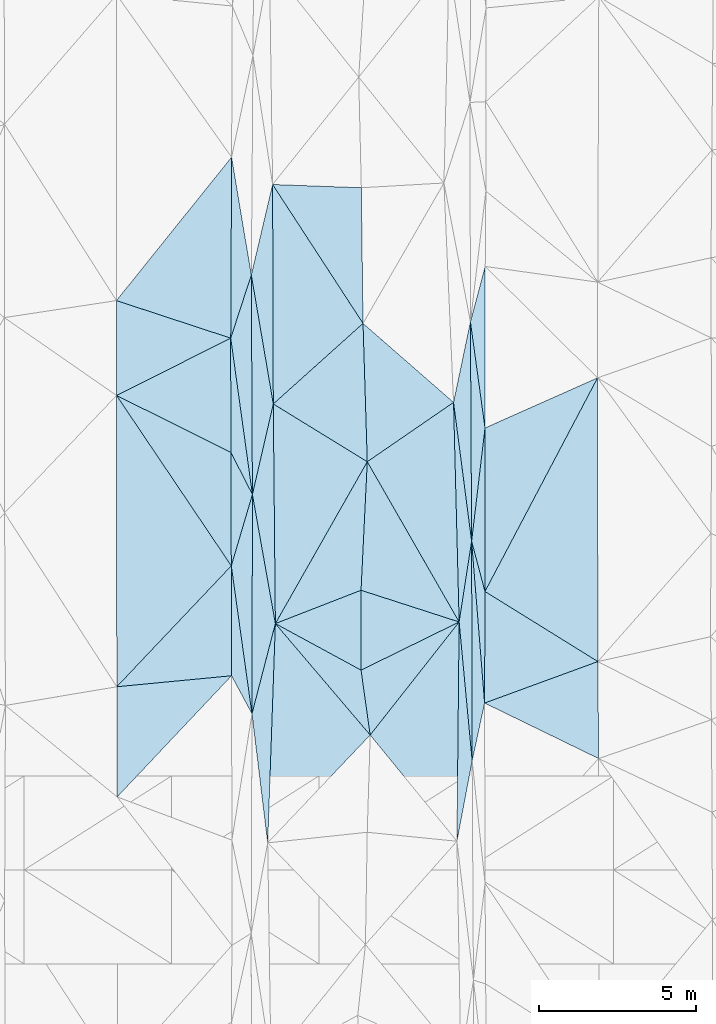
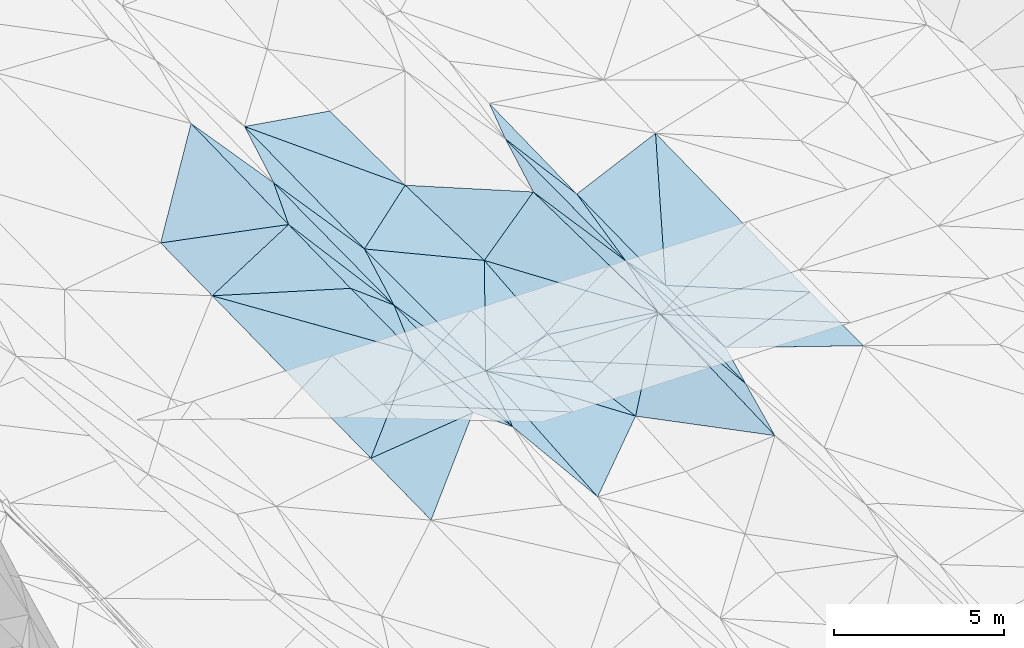
# One storey, part 108 of 275: 45 plates.
"""IFC2X3 building model written with IfcOpenShell, lengths in millimetres."""

from ifc_helpers import new_model, si_unit, frame, origin_with_axes, place, context, subcontext, project, spatial, polyline, outline, extrude, material, type_object, element, save


model = new_model("IFC2X3")

# Units and contexts
model_context = context("Model", 3, precision=1e-05, world=origin_with_axes())
body_context = subcontext(model_context, "Body", "Model", "MODEL_VIEW")
ifc_project = project(units=[si_unit("LENGTHUNIT", "METRE", prefix="MILLI"), si_unit("AREAUNIT", "SQUARE_METRE"), si_unit("VOLUMEUNIT", "CUBIC_METRE"), si_unit("MASSUNIT", "GRAM", prefix="KILO"), si_unit("TIMEUNIT", "SECOND"), si_unit("PLANEANGLEUNIT", "RADIAN"), si_unit("SOLIDANGLEUNIT", "STERADIAN"), si_unit("THERMODYNAMICTEMPERATUREUNIT", "DEGREE_CELSIUS"), si_unit("LUMINOUSINTENSITYUNIT", "LUMEN")], contexts=[model_context])

# Site, building, storey
site_placement = place(None, origin_with_axes())
site = spatial("IfcSite", under=ifc_project, at=site_placement, CompositionType="ELEMENT")
building_placement = place(site_placement, origin_with_axes())
building = spatial("IfcBuilding", under=site, at=building_placement, Name="Undefined", CompositionType="ELEMENT")
storey_placement = place(building_placement, origin_with_axes())
storey = spatial("IfcBuildingStorey", under=building, at=storey_placement, Name="Undefined", CompositionType="ELEMENT", Elevation=0.0)

# Plates
ifc_material = material()
plate_type_1 = type_object("IfcPlateType", PredefinedType="NOTDEFINED")
plate_1_placement = place(storey_placement, frame((-72857.8728708882, 71200.3635232612, 42820.5068189035), z_axis=(0.163382839514958, 0.0207850370122692, -0.986343768667105), x_axis=(-0.0100323754540099, -0.999691344366781, -0.022728120047394)))
element("IfcPlate", 1, at=plate_1_placement, inside=storey, type_object=plate_type_1, material=ifc_material, Name="00", context=body_context, shape_type="SweptSolid", body=[
    extrude(outline(polyline([(0.0, 0.0), (6995.7392578125, -1.95213942788541e-08), (3644.97436523438, 2839.29345703125), (0.0, 0.0)])), frame((-8.85201319254618e-08, 2.18876761149539e-07, -0.5000001331573), z_axis=(0.0, 0.0, 1.0), x_axis=(1.0, 0.0, 0.0)), (0.0, 0.0, 1.0), 1.0),
])
plate_type_2 = type_object("IfcPlateType", PredefinedType="NOTDEFINED")
plate_2_placement = place(storey_placement, frame((-79451.9608102486, 75268.5090388455, 42914.5001193451), z_axis=(0.00661582862626552, 0.0219756908270818, -0.999736615226361), x_axis=(-0.456254255472781, 0.889695770643281, 0.0165375349565078)))
element("IfcPlate", 2, at=plate_2_placement, inside=storey, type_object=plate_type_2, material=ifc_material, Name="00", context=body_context, shape_type="SweptSolid", body=[
    extrude(outline(polyline([(0.0, 0.0), (1511.71264648438, 4.15457179769874e-09), (4752.4609375, 1659.44287109375), (0.0, 0.0)])), frame((-8.85201319254618e-08, 2.18876761149539e-07, -0.5000001331573), z_axis=(0.0, 0.0, 1.0), x_axis=(1.0, 0.0, 0.0)), (0.0, 0.0, 1.0), 1.0),
])
plate_type_3 = type_object("IfcPlateType", PredefinedType="NOTDEFINED")
plate_3_placement = place(storey_placement, frame((-68432.6148026348, 69937.9228336085, 42759.5002629665), z_axis=(-0.0265998288897072, 0.0197490811271896, -0.999451060781702), x_axis=(-0.938788525447219, -0.344013537513872, 0.0181876467919163)))
element("IfcPlate", 3, at=plate_3_placement, inside=storey, type_object=plate_type_3, material=ifc_material, Name="00", context=body_context, shape_type="SweptSolid", body=[
    extrude(outline(polyline([(0.0, 0.0), (3848.76611328125, 1.68802216649055e-09), (2614.4482421875, 3338.61645507813), (0.0, 0.0)])), frame((-8.85201319254618e-08, 2.18876761149539e-07, -0.5000001331573), z_axis=(0.0, 0.0, 1.0), x_axis=(1.0, 0.0, 0.0)), (0.0, 0.0, 1.0), 1.0),
])
plate_type_4 = type_object("IfcPlateType", PredefinedType="NOTDEFINED")
plate_4_placement = place(storey_placement, frame((-80116.0807618143, 86027.7293392564, 43129.5004073985), z_axis=(0.0363448309060378, 0.0188605692333004, -0.999161314400536), x_axis=(-0.00477584441094, -0.999807192790456, -0.0190464840490176)))
element("IfcPlate", 4, at=plate_4_placement, inside=storey, type_object=plate_type_4, material=ifc_material, Name="00", context=body_context, shape_type="SweptSolid", body=[
    extrude(outline(polyline([(0.0, 0.0), (5775.34423828125, 8.13452061265707e-09), (4596.9208984375, 3653.87719726563), (0.0, 0.0)])), frame((-8.85201319254618e-08, 2.18876761149539e-07, -0.5000001331573), z_axis=(0.0, 0.0, 1.0), x_axis=(1.0, 0.0, 0.0)), (0.0, 0.0, 1.0), 1.0),
])
plate_type_5 = type_object("IfcPlateType", PredefinedType="NOTDEFINED")
plate_5_placement = place(storey_placement, frame((-80125.4359483068, 72990.6765646459, 42859.500226889), z_axis=(0.0262424867575079, 0.0163751317635468, -0.999521478983072), x_axis=(0.2834598154468, 0.958704684194832, 0.0231486831105507)))
element("IfcPlate", 5, at=plate_5_placement, inside=storey, type_object=plate_type_5, material=ifc_material, Name="00", context=body_context, shape_type="SweptSolid", body=[
    extrude(outline(polyline([(0.0, 0.0), (2375.94506835938, -1.05355866253376e-08), (-4338.8623046875, 1970.98706054688), (0.0, 0.0)])), frame((-8.85201319254618e-08, 2.18876761149539e-07, -0.5000001331573), z_axis=(0.0, 0.0, 1.0), x_axis=(1.0, 0.0, 0.0)), (0.0, 0.0, 1.0), 1.0),
])
plate_type_6 = type_object("IfcPlateType", PredefinedType="NOTDEFINED")
plate_6_placement = place(storey_placement, frame((-80143.6796963397, 80253.5000110002, 43019.5001044803), z_axis=(0.00276311446801479, 0.0214417133830076, -0.999766281750709), x_axis=(0.31008959754468, 0.950470010515551, 0.0212414831202224)))
element("IfcPlate", 6, at=plate_6_placement, inside=storey, type_object=plate_type_6, material=ifc_material, Name="00", context=body_context, shape_type="SweptSolid", body=[
    extrude(outline(polyline([(0.0, 0.0), (2118.49609375, 6.88305590301752e-09), (-4525.82080078125, 2203.76513671875), (0.0, 0.0)])), frame((-8.85201319254618e-08, 2.18876761149539e-07, -0.5000001331573), z_axis=(0.0, 0.0, 1.0), x_axis=(1.0, 0.0, 0.0)), (0.0, 0.0, 1.0), 1.0),
])
plate_type_7 = type_object("IfcPlateType", PredefinedType="NOTDEFINED")
plate_7_placement = place(storey_placement, frame((-79451.9889511648, 75268.5086278092, 42914.5007184932), z_axis=(-0.0496778021210665, 0.0211547469191174, -0.998541232328044), x_axis=(-0.00497029753528629, 0.99975804349267, 0.0214278000298448)))
element("IfcPlate", 7, at=plate_7_placement, inside=storey, type_object=plate_type_7, material=ifc_material, Name="00", context=body_context, shape_type="SweptSolid", body=[
    extrude(outline(polyline([(0.0, 0.0), (7000.251953125, 4.68135112896562e-08), (2882.32446289063, 681.223510742188), (0.0, 0.0)])), frame((-8.85201319254618e-08, 2.18876761149539e-07, -0.5000001331573), z_axis=(0.0, 0.0, 1.0), x_axis=(1.0, 0.0, 0.0)), (0.0, 0.0, 1.0), 1.0),
])
plate_type_8 = type_object("IfcPlateType", PredefinedType="NOTDEFINED")
plate_8_placement = place(storey_placement, frame((-72033.7376675861, 72172.6673554907, 42899.5006058297), z_axis=(-0.0449430024337479, 0.0210730985098259, -0.998767265708801), x_axis=(-0.25649921547482, 0.966017080441057, 0.0319241719851723)))
element("IfcPlate", 8, at=plate_8_placement, inside=storey, type_object=plate_type_8, material=ifc_material, Name="00", context=body_context, shape_type="SweptSolid", body=[
    extrude(outline(polyline([(0.0, 0.0), (1660.18408203125, 3.14321368932724e-09), (5041.82080078125, 1340.57641601563), (0.0, 0.0)])), frame((-8.85201319254618e-08, 2.18876761149539e-07, -0.5000001331573), z_axis=(0.0, 0.0, 1.0), x_axis=(1.0, 0.0, 0.0)), (0.0, 0.0, 1.0), 1.0),
])
plate_type_9 = type_object("IfcPlateType", PredefinedType="NOTDEFINED")
plate_9_placement = place(storey_placement, frame((-72442.4501093722, 66773.3408617365, 42803.5003700226), z_axis=(-0.0327809613251292, 0.0211799794004191, -0.99923811829173), x_axis=(-0.00244369959772996, 0.999770750871483, 0.0212714370493995)))
element("IfcPlate", 9, at=plate_9_placement, inside=storey, type_object=plate_type_9, material=ifc_material, Name="00", context=body_context, shape_type="SweptSolid", body=[
    extrude(outline(polyline([(0.0, 0.0), (7004.69873046875, -9.50240064412355e-09), (1839.71691894531, 401.367462158203), (0.0, 0.0)])), frame((-8.85201319254618e-08, 2.18876761149539e-07, -0.5000001331573), z_axis=(0.0, 0.0, 1.0), x_axis=(1.0, 0.0, 0.0)), (0.0, 0.0, 1.0), 1.0),
])
plate_type_10 = type_object("IfcPlateType", PredefinedType="NOTDEFINED")
plate_10_placement = place(storey_placement, frame((-75788.1193262219, 76312.1021307502, 42598.5034495006), z_axis=(-0.114202995446313, 0.027336586494193, -0.993081258946082), x_axis=(-0.0484452834658263, -0.998585350156554, -0.0219169560529661)))
element("IfcPlate", 10, at=plate_10_placement, inside=storey, type_object=plate_type_10, material=ifc_material, Name="00", context=body_context, shape_type="SweptSolid", body=[
    extrude(outline(polyline([(0.0, 0.0), (4106.40966796875, -5.67524693906307e-10), (5293.72412109375, 2695.96728515625), (0.0, 0.0)])), frame((-8.85201319254618e-08, 2.18876761149539e-07, -0.5000001331573), z_axis=(0.0, 0.0, 1.0), x_axis=(1.0, 0.0, 0.0)), (0.0, 0.0, 1.0), 1.0),
])
plate_type_11 = type_object("IfcPlateType", PredefinedType="NOTDEFINED")
plate_11_placement = place(storey_placement, frame((-80141.6859915911, 76613.4734157735, 42939.5001215529), z_axis=(0.00687262350337496, 0.0221072943769802, -0.999731981373763), x_axis=(0.45625425547646, -0.889695770641418, -0.0165375349552217)))
element("IfcPlate", 11, at=plate_11_placement, inside=storey, type_object=plate_type_11, material=ifc_material, Name="00", context=body_context, shape_type="SweptSolid", body=[
    extrude(outline(polyline([(0.0, 0.0), (1511.71264648438, 4.15457179769874e-09), (3231.91723632813, 1638.90539550781), (0.0, 0.0)])), frame((-8.85201319254618e-08, 2.18876761149539e-07, -0.5000001331573), z_axis=(0.0, 0.0, 1.0), x_axis=(1.0, 0.0, 0.0)), (0.0, 0.0, 1.0), 1.0),
])
plate_type_12 = type_object("IfcPlateType", PredefinedType="NOTDEFINED")
plate_12_placement = place(storey_placement, frame((-78964.5476860163, 64154.5708718856, 42611.5040899322), z_axis=(-0.124258073772401, 0.0301572693350512, -0.991791545743674), x_axis=(-0.120780756459142, 0.991645740550093, 0.0452850319423066)))
element("IfcPlate", 12, at=plate_12_placement, inside=storey, type_object=plate_type_12, material=ifc_material, Name="00", context=body_context, shape_type="SweptSolid", body=[
    extrude(outline(polyline([(0.0, 0.0), (4151.48193359375, 6.98491930961609e-10), (6914.49267578125, 1096.55187988281), (0.0, 0.0)])), frame((-8.85201319254618e-08, 2.18876761149539e-07, -0.5000001331573), z_axis=(0.0, 0.0, 1.0), x_axis=(1.0, 0.0, 0.0)), (0.0, 0.0, 1.0), 1.0),
])
plate_type_13 = type_object("IfcPlateType", PredefinedType="NOTDEFINED")
plate_13_placement = place(storey_placement, frame((-72442.3400560563, 66773.3409452281, 42803.5089563481), z_axis=(0.187315329686238, 0.021352629379972, -0.982067733144256), x_axis=(-0.0934486975000331, 0.995616755542285, 0.00382322102427208)))
element("IfcPlate", 13, at=plate_13_placement, inside=storey, type_object=plate_type_13, material=ifc_material, Name="00", context=body_context, shape_type="SweptSolid", body=[
    extrude(outline(polyline([(0.0, 0.0), (4446.51318359375, 3.11047188006341e-08), (6974.5654296875, 649.026062011719), (0.0, 0.0)])), frame((-8.85201319254618e-08, 2.18876761149539e-07, -0.5000001331573), z_axis=(0.0, 0.0, 1.0), x_axis=(1.0, 0.0, 0.0)), (0.0, 0.0, 1.0), 1.0),
])
plate_type_14 = type_object("IfcPlateType", PredefinedType="NOTDEFINED")
plate_14_placement = place(storey_placement, frame((-72928.0490013595, 64206.7833467757, 42661.5081633929), z_axis=(0.178893221706957, 0.0205682188323153, -0.983653477400132), x_axis=(0.0100323754560474, 0.999691344367152, 0.0227281200301465)))
element("IfcPlate", 14, at=plate_14_placement, inside=storey, type_object=plate_type_14, material=ifc_material, Name="00", context=body_context, shape_type="SweptSolid", body=[
    extrude(outline(polyline([(0.0, 0.0), (6995.7392578125, -1.95213942788541e-08), (2573.865234375, 467.447296142578), (0.0, 0.0)])), frame((-8.85201319254618e-08, 2.18876761149539e-07, -0.5000001331573), z_axis=(0.0, 0.0, 1.0), x_axis=(1.0, 0.0, 0.0)), (0.0, 0.0, 1.0), 1.0),
])
plate_type_15 = type_object("IfcPlateType", PredefinedType="NOTDEFINED")
plate_15_placement = place(storey_placement, frame((-75987.0012267293, 69663.9851055878, 42344.5061495304), z_axis=(-0.156066222917514, 0.0114360040365097, -0.987680389536989), x_axis=(0.139399294462836, -0.989669909413387, -0.0334859239825032)))
element("IfcPlate", 15, at=plate_15_placement, inside=storey, type_object=plate_type_15, material=ifc_material, Name="00", context=body_context, shape_type="SweptSolid", body=[
    extrude(outline(polyline([(0.0, 0.0), (2090.4306640625, -1.05646904557943e-08), (-1865.46740722656, 2528.67602539063), (0.0, 0.0)])), frame((-8.85201319254618e-08, 2.18876761149539e-07, -0.5000001331573), z_axis=(0.0, 0.0, 1.0), x_axis=(1.0, 0.0, 0.0)), (0.0, 0.0, 1.0), 1.0),
])
plate_type_16 = type_object("IfcPlateType", PredefinedType="NOTDEFINED")
plate_16_placement = place(storey_placement, frame((-79465.8887089548, 68271.3639608554, 42799.5003174788), z_axis=(0.0320064093374872, 0.017178357921229, -0.999340029109438), x_axis=(-0.472907201462392, 0.881112239618205, -4.77451848829258e-11)))
element("IfcPlate", 16, at=plate_16_placement, inside=storey, type_object=plate_type_16, material=ifc_material, Name="00", context=body_context, shape_type="SweptSolid", body=[
    extrude(outline(polyline([(0.0, 0.0), (1377.00903320313, -1.03027559816837e-08), (4470.14794921875, 1651.75463867188), (0.0, 0.0)])), frame((-8.85201319254618e-08, 2.18876761149539e-07, -0.5000001331573), z_axis=(0.0, 0.0, 1.0), x_axis=(1.0, 0.0, 0.0)), (0.0, 0.0, 1.0), 1.0),
])
plate_type_17 = type_object("IfcPlateType", PredefinedType="NOTDEFINED")
plate_17_placement = place(storey_placement, frame((-72857.8615490669, 71200.363916149, 42820.5088364232), z_axis=(0.186026571524622, 0.0215642566052026, -0.98230804614635), x_axis=(-0.0254378945506109, 0.999529713962518, 0.0171249650171869)))
element("IfcPlate", 17, at=plate_17_placement, inside=storey, type_object=plate_type_17, material=ifc_material, Name="00", context=body_context, shape_type="SweptSolid", body=[
    extrude(outline(polyline([(0.0, 0.0), (7007.3134765625, -2.31739250011742e-08), (2566.984375, 472.098236083984), (0.0, 0.0)])), frame((-8.85201319254618e-08, 2.18876761149539e-07, -0.5000001331573), z_axis=(0.0, 0.0, 1.0), x_axis=(1.0, 0.0, 0.0)), (0.0, 0.0, 1.0), 1.0),
])
plate_type_18 = type_object("IfcPlateType", PredefinedType="NOTDEFINED")
plate_18_placement = place(storey_placement, frame((-72045.803731531, 68613.8952442671, 42829.5007033956), z_axis=(-0.0496755244645198, 0.0198099526394931, -0.998568930042186), x_axis=(-0.0798702746437501, 0.996522466564578, 0.0237426380248853)))
element("IfcPlate", 18, at=plate_18_placement, inside=storey, type_object=plate_type_18, material=ifc_material, Name="00", context=body_context, shape_type="SweptSolid", body=[
    extrude(outline(polyline([(0.0, 0.0), (5180.55322265625, 2.29192664846778e-08), (3547.09423828125, 296.686370849609), (0.0, 0.0)])), frame((-8.85201319254618e-08, 2.18876761149539e-07, -0.5000001331573), z_axis=(0.0, 0.0, 1.0), x_axis=(1.0, 0.0, 0.0)), (0.0, 0.0, 1.0), 1.0),
])
plate_type_19 = type_object("IfcPlateType", PredefinedType="NOTDEFINED")
plate_19_placement = place(storey_placement, frame((-72857.9022795684, 71200.3615100847, 42820.5028025911), z_axis=(0.104563570142122, 0.0167518060830626, -0.994377109949786), x_axis=(-0.947297248148376, 0.306114359505968, -0.0944559291668124)))
element("IfcPlate", 19, at=plate_19_placement, inside=storey, type_object=plate_type_19, material=ifc_material, Name="00", context=body_context, shape_type="SweptSolid", body=[
    extrude(outline(polyline([(0.0, 0.0), (3303.12768554688, 6.29370333626866e-09), (4361.427734375, 3967.69458007813), (0.0, 0.0)])), frame((-8.85201319254618e-08, 2.18876761149539e-07, -0.5000001331573), z_axis=(0.0, 0.0, 1.0), x_axis=(1.0, 0.0, 0.0)), (0.0, 0.0, 1.0), 1.0),
])
plate_type_20 = type_object("IfcPlateType", PredefinedType="NOTDEFINED")
plate_20_placement = place(storey_placement, frame((-72459.5670428774, 73776.4327170666, 42952.5003377471), z_axis=(-0.0318865400626018, 0.0195382723737591, -0.999300507592929), x_axis=(-0.00543729468210168, 0.999790730093737, 0.0197213550541615)))
element("IfcPlate", 20, at=plate_20_placement, inside=storey, type_object=plate_type_20, material=ifc_material, Name="00", context=body_context, shape_type="SweptSolid", body=[
    extrude(outline(polyline([(0.0, 0.0), (6997.49072265625, -6.11180439591408e-09), (3610.12182617188, 446.801147460938), (0.0, 0.0)])), frame((-8.85201319254618e-08, 2.18876761149539e-07, -0.5000001331573), z_axis=(0.0, 0.0, 1.0), x_axis=(1.0, 0.0, 0.0)), (0.0, 0.0, 1.0), 1.0),
])
plate_type_21 = type_object("IfcPlateType", PredefinedType="NOTDEFINED")
plate_21_placement = place(storey_placement, frame((-72032.6153777705, 77388.5096025226, 43009.5001307363), z_axis=(-0.00467191600541404, 0.0232877985675683, -0.99971788602521), x_axis=(-0.136091631589599, 0.990412562913072, 0.0237070250187935)))
element("IfcPlate", 21, at=plate_21_placement, inside=storey, type_object=plate_type_21, material=ifc_material, Name="00", context=body_context, shape_type="SweptSolid", body=[
    extrude(outline(polyline([(0.0, 0.0), (3416.70874023438, 1.91357685253024e-08), (5105.357421875, 708.466247558594), (0.0, 0.0)])), frame((-8.85201319254618e-08, 2.18876761149539e-07, -0.5000001331573), z_axis=(0.0, 0.0, 1.0), x_axis=(1.0, 0.0, 0.0)), (0.0, 0.0, 1.0), 1.0),
])
plate_type_22 = type_object("IfcPlateType", PredefinedType="NOTDEFINED")
plate_22_placement = place(storey_placement, frame((-78785.940705745, 78154.2418636119, 42942.5007074029), z_axis=(-0.0491686118732934, 0.0212422067583242, -0.998564577910958), x_axis=(-0.167910658613879, 0.985368793326076, 0.0292292980238384)))
element("IfcPlate", 22, at=plate_22_placement, inside=storey, type_object=plate_type_22, material=ifc_material, Name="00", context=body_context, shape_type="SweptSolid", body=[
    extrude(outline(polyline([(0.0, 0.0), (4173.89404296875, 7.82893039286137e-09), (6906.6630859375, 1155.84045410156), (0.0, 0.0)])), frame((-8.85201319254618e-08, 2.18876761149539e-07, -0.5000001331573), z_axis=(0.0, 0.0, 1.0), x_axis=(1.0, 0.0, 0.0)), (0.0, 0.0, 1.0), 1.0),
])
plate_type_23 = type_object("IfcPlateType", PredefinedType="NOTDEFINED")
plate_23_placement = place(storey_placement, frame((-72459.4626377951, 73776.433130087, 42952.5079824786), z_axis=(0.176909517488415, 0.0203723067091441, -0.984016255831866), x_axis=(-0.129139717524187, 0.991622766719076, -0.00268735598294316)))
element("IfcPlate", 23, at=plate_23_placement, inside=storey, type_object=plate_type_23, material=ifc_material, Name="00", context=body_context, shape_type="SweptSolid", body=[
    extrude(outline(polyline([(0.0, 0.0), (4465.35595703125, 1.79861672222614e-08), (6941.96142578125, 879.798645019531), (0.0, 0.0)])), frame((-8.85201319254618e-08, 2.18876761149539e-07, -0.5000001331573), z_axis=(0.0, 0.0, 1.0), x_axis=(1.0, 0.0, 0.0)), (0.0, 0.0, 1.0), 1.0),
])
plate_type_24 = type_object("IfcPlateType", PredefinedType="NOTDEFINED")
plate_24_placement = place(storey_placement, frame((-78719.6845100735, 71148.8187317578, 42793.5006719619), z_axis=(-0.0480738233595712, 0.020785373581348, -0.998627495992713), x_axis=(-0.174940363435964, 0.98415462557204, 0.0289057469381124)))
element("IfcPlate", 24, at=plate_24_placement, inside=storey, type_object=plate_type_24, material=ifc_material, Name="00", context=body_context, shape_type="SweptSolid", body=[
    extrude(outline(polyline([(0.0, 0.0), (4186.0185546875, -4.86033968627453e-09), (6910.31689453125, 1161.92016601563), (0.0, 0.0)])), frame((-8.85201319254618e-08, 2.18876761149539e-07, -0.5000001331573), z_axis=(0.0, 0.0, 1.0), x_axis=(1.0, 0.0, 0.0)), (0.0, 0.0, 1.0), 1.0),
])
plate_type_25 = type_object("IfcPlateType", PredefinedType="NOTDEFINED")
plate_25_placement = place(storey_placement, frame((-68442.261996962, 78986.7249079721, 42959.5002361264), z_axis=(-0.0233046837439812, 0.021084106434246, -0.999506054094452), x_axis=(-0.466252604357294, -0.884617338202201, -0.00778934413752393)))
element("IfcPlate", 25, at=plate_25_placement, inside=storey, type_object=plate_type_25, material=ifc_material, Name="00", context=body_context, shape_type="SweptSolid", body=[
    extrude(outline(polyline([(0.0, 0.0), (7702.83056640625, 7.49423634260893e-09), (3087.4365234375, 2432.1259765625), (0.0, 0.0)])), frame((-8.85201319254618e-08, 2.18876761149539e-07, -0.5000001331573), z_axis=(0.0, 0.0, 1.0), x_axis=(1.0, 0.0, 0.0)), (0.0, 0.0, 1.0), 1.0),
])
plate_type_26 = type_object("IfcPlateType", PredefinedType="NOTDEFINED")
plate_26_placement = place(storey_placement, frame((-72857.8996368417, 71200.3630505297, 42820.5031147477), z_axis=(0.109872279378804, 0.0198221417804709, -0.993748038951193), x_axis=(-0.496952212541626, 0.866960697850802, -0.0376516511196168)))
element("IfcPlate", 26, at=plate_26_placement, inside=storey, type_object=plate_type_26, material=ifc_material, Name="00", context=body_context, shape_type="SweptSolid", body=[
    extrude(outline(polyline([(0.0, 0.0), (5896.15576171875, -1.35478330776095e-08), (6156.27294921875, 3347.05102539063), (0.0, 0.0)])), frame((-8.85201319254618e-08, 2.18876761149539e-07, -0.5000001331573), z_axis=(0.0, 0.0, 1.0), x_axis=(1.0, 0.0, 0.0)), (0.0, 0.0, 1.0), 1.0),
])
plate_type_27 = type_object("IfcPlateType", PredefinedType="NOTDEFINED")
plate_27_placement = place(storey_placement, frame((-72045.7920887411, 68613.8949283331, 42829.5002539305), z_axis=(-0.0263907341688428, 0.019177595042421, -0.999467732845047), x_axis=(0.938788525449475, 0.34401353750774, -0.0181876467914759)))
element("IfcPlate", 27, at=plate_27_placement, inside=storey, type_object=plate_type_27, material=ifc_material, Name="00", context=body_context, shape_type="SweptSolid", body=[
    extrude(outline(polyline([(0.0, 0.0), (3848.76611328125, 1.68802216649055e-09), (2807.13354492188, 2914.97875976563), (0.0, 0.0)])), frame((-8.85201319254618e-08, 2.18876761149539e-07, -0.5000001331573), z_axis=(0.0, 0.0, 1.0), x_axis=(1.0, 0.0, 0.0)), (0.0, 0.0, 1.0), 1.0),
])
plate_type_28 = type_object("IfcPlateType", PredefinedType="NOTDEFINED")
plate_28_placement = place(storey_placement, frame((-83765.7116259615, 65619.2934142019, 42569.5004700563), z_axis=(0.0357447426467153, 0.0257045563899783, -0.999030324441613), x_axis=(-0.00352363764087708, 0.999666188277589, 0.0255948430808388)))
element("IfcPlate", 28, at=plate_28_placement, inside=storey, type_object=plate_type_28, material=ifc_material, Name="00", context=body_context, shape_type="SweptSolid", body=[
    extrude(outline(polyline([(0.0, 0.0), (3516.33325195313, 1.44063960760832e-09), (3857.11450195313, 3664.5830078125), (0.0, 0.0)])), frame((-8.85201319254618e-08, 2.18876761149539e-07, -0.5000001331573), z_axis=(0.0, 0.0, 1.0), x_axis=(1.0, 0.0, 0.0)), (0.0, 0.0, 1.0), 1.0),
])
plate_type_29 = type_object("IfcPlateType", PredefinedType="NOTDEFINED")
plate_29_placement = place(storey_placement, frame((-83785.2451658041, 78424.8993557023, 42849.5004210201), z_axis=(0.0366713398735263, 0.0198569458985719, -0.999130078884357), x_axis=(-0.00139099063542318, 0.999802611596243, 0.0198192580684552)))
element("IfcPlate", 29, at=plate_29_placement, inside=storey, type_object=plate_type_29, material=ifc_material, Name="00", context=body_context, shape_type="SweptSolid", body=[
    extrude(outline(polyline([(0.0, 0.0), (3027.35864257813, 2.2017047740519e-08), (1826.54284667969, 3646.57934570313), (0.0, 0.0)])), frame((-8.85201319254618e-08, 2.18876761149539e-07, -0.5000001331573), z_axis=(0.0, 0.0, 1.0), x_axis=(1.0, 0.0, 0.0)), (0.0, 0.0, 1.0), 1.0),
])
plate_type_30 = type_object("IfcPlateType", PredefinedType="NOTDEFINED")
plate_30_placement = place(storey_placement, frame((-83785.2469439661, 78424.8996583117, 42849.5003640726), z_axis=(0.0331116282002015, 0.0204610722059364, -0.999242195166975), x_axis=(0.558603184436654, -0.829433633690053, 0.00152631613529474)))
element("IfcPlate", 30, at=plate_30_placement, inside=storey, type_object=plate_type_30, material=ifc_material, Name="00", context=body_context, shape_type="SweptSolid", body=[
    extrude(outline(polyline([(0.0, 0.0), (6551.72509765625, 3.82169673684984e-08), (7709.51171875, 5187.6806640625), (0.0, 0.0)])), frame((-8.85201319254618e-08, 2.18876761149539e-07, -0.5000001331573), z_axis=(0.0, 0.0, 1.0), x_axis=(1.0, 0.0, 0.0)), (0.0, 0.0, 1.0), 1.0),
])
plate_type_31 = type_object("IfcPlateType", PredefinedType="NOTDEFINED")
plate_31_placement = place(storey_placement, frame((-83785.2456350324, 78424.9005339041, 42849.5004297011), z_axis=(0.0357274635588634, 0.0222230091416686, -0.999114451007661), x_axis=(0.895224342109286, -0.445066730400828, 0.0221129551465145)))
element("IfcPlate", 31, at=plate_31_placement, inside=storey, type_object=plate_type_31, material=ifc_material, Name="00", context=body_context, shape_type="SweptSolid", body=[
    extrude(outline(polyline([(0.0, 0.0), (4070.01220703125, 1.03245838545263e-08), (5695.1669921875, 3238.853515625), (0.0, 0.0)])), frame((-8.85201319254618e-08, 2.18876761149539e-07, -0.5000001331573), z_axis=(0.0, 0.0, 1.0), x_axis=(1.0, 0.0, 0.0)), (0.0, 0.0, 1.0), 1.0),
])
plate_type_32 = type_object("IfcPlateType", PredefinedType="NOTDEFINED")
plate_32_placement = place(storey_placement, frame((-80125.4307876458, 72990.676970566, 42859.5003957481), z_axis=(0.0365654367937735, 0.0171865324333668, -0.999183462600837), x_axis=(0.00238036858637062, -0.99985076433658, -0.0171109000625408)))
element("IfcPlate", 32, at=plate_32_placement, inside=storey, type_object=plate_type_32, material=ifc_material, Name="00", context=body_context, shape_type="SweptSolid", body=[
    extrude(outline(polyline([(0.0, 0.0), (3506.53686523438, -2.17260094359517e-08), (3850.38037109375, 3664.296875), (0.0, 0.0)])), frame((-8.85201319254618e-08, 2.18876761149539e-07, -0.5000001331573), z_axis=(0.0, 0.0, 1.0), x_axis=(1.0, 0.0, 0.0)), (0.0, 0.0, 1.0), 1.0),
])
plate_type_33 = type_object("IfcPlateType", PredefinedType="NOTDEFINED")
plate_33_placement = place(storey_placement, frame((-68442.2629236206, 78986.7253943424, 42959.5002706804), z_axis=(-0.0251633436324293, 0.0220631627895363, -0.999439854611051), x_axis=(0.00106605060494976, -0.999755263865909, -0.0220969660477127)))
element("IfcPlate", 33, at=plate_33_placement, inside=storey, type_object=plate_type_33, material=ifc_material, Name="00", context=body_context, shape_type="SweptSolid", body=[
    extrude(outline(polyline([(0.0, 0.0), (9051.0166015625, -5.84259396418929e-08), (6809.88720703125, 3599.86645507813), (0.0, 0.0)])), frame((-8.85201319254618e-08, 2.18876761149539e-07, -0.5000001331573), z_axis=(0.0, 0.0, 1.0), x_axis=(1.0, 0.0, 0.0)), (0.0, 0.0, 1.0), 1.0),
])
plate_type_34 = type_object("IfcPlateType", PredefinedType="NOTDEFINED")
plate_34_placement = place(storey_placement, frame((-75978.1004896185, 85051.5678569146, 42717.5043254053), z_axis=(-0.131003427201009, 0.0102634428984741, -0.991328786932701), x_axis=(0.0125815925230739, -0.999848668611798, -0.0120143000128477)))
element("IfcPlate", 34, at=plate_34_placement, inside=storey, type_object=plate_type_34, material=ifc_material, Name="00", context=body_context, shape_type="SweptSolid", body=[
    extrude(outline(polyline([(0.0, 0.0), (4328.17578125, -1.90630089491606e-08), (-143.829650878906, 2852.57348632813), (0.0, 0.0)])), frame((-8.85201319254618e-08, 2.18876761149539e-07, -0.5000001331573), z_axis=(0.0, 0.0, 1.0), x_axis=(1.0, 0.0, 0.0)), (0.0, 0.0, 1.0), 1.0),
])
plate_type_35 = type_object("IfcPlateType", PredefinedType="NOTDEFINED")
plate_35_placement = place(storey_placement, frame((-75788.1130839039, 76312.0985619526, 42598.5026858561), z_axis=(-0.101721993359148, 0.0201924882612032, -0.994607912438295), x_axis=(-0.49347803362701, -0.869138644400216, 0.0328244899088393)))
element("IfcPlate", 35, at=plate_35_placement, inside=storey, type_object=plate_type_35, material=ifc_material, Name="00", context=body_context, shape_type="SweptSolid", body=[
    extrude(outline(polyline([(0.0, 0.0), (5940.6865234375, -4.68426151201129e-08), (-110.41081237793, 3533.66137695313), (0.0, 0.0)])), frame((-8.85201319254618e-08, 2.18876761149539e-07, -0.5000001331573), z_axis=(0.0, 0.0, 1.0), x_axis=(1.0, 0.0, 0.0)), (0.0, 0.0, 1.0), 1.0),
])
plate_type_36 = type_object("IfcPlateType", PredefinedType="NOTDEFINED")
plate_36_placement = place(storey_placement, frame((-79465.9405904968, 68271.3636390673, 42799.5013469021), z_axis=(-0.071770684661681, 0.0165336342350348, -0.997284115867778), x_axis=(0.00199205346788074, 0.999862984269786, 0.0164330280258543)))
element("IfcPlate", 36, at=plate_36_placement, inside=storey, type_object=plate_type_36, material=ifc_material, Name="00", context=body_context, shape_type="SweptSolid", body=[
    extrude(outline(polyline([(0.0, 0.0), (6998.1015625, 4.92145773023367e-08), (2878.44677734375, 742.42626953125), (0.0, 0.0)])), frame((-8.85201319254618e-08, 2.18876761149539e-07, -0.5000001331573), z_axis=(0.0, 0.0, 1.0), x_axis=(1.0, 0.0, 0.0)), (0.0, 0.0, 1.0), 1.0),
])
plate_type_37 = type_object("IfcPlateType", PredefinedType="NOTDEFINED")
plate_37_placement = place(storey_placement, frame((-75695.4558602823, 67595.1687484199, 42274.5046096267), z_axis=(0.125576046824015, 0.0512107846409479, -0.990761379950042), x_axis=(-0.139399294466566, 0.989669909412398, 0.0334859239961992)))
element("IfcPlate", 37, at=plate_37_placement, inside=storey, type_object=plate_type_37, material=ifc_material, Name="00", context=body_context, shape_type="SweptSolid", body=[
    extrude(outline(polyline([(0.0, 0.0), (2090.4306640625, -1.05646904557943e-08), (3190.69677734375, 3341.68798828125), (0.0, 0.0)])), frame((-8.85201319254618e-08, 2.18876761149539e-07, -0.5000001331573), z_axis=(0.0, 0.0, 1.0), x_axis=(1.0, 0.0, 0.0)), (0.0, 0.0, 1.0), 1.0),
])
plate_type_38 = type_object("IfcPlateType", PredefinedType="NOTDEFINED")
plate_38_placement = place(storey_placement, frame((-75695.5857398232, 67595.1583787918, 42274.5047458501), z_axis=(-0.134180496106212, 0.0304706799728672, -0.990488330131497), x_axis=(-0.687064774570207, -0.723135610323054, 0.0708299698397068)))
element("IfcPlate", 38, at=plate_38_placement, inside=storey, type_object=plate_type_38, material=ifc_material, Name="00", context=body_context, shape_type="SweptSolid", body=[
    extrude(outline(polyline([(0.0, 0.0), (4757.873046875, 6.24277163296938e-09), (-455.239776611328, 4672.91015625), (0.0, 0.0)])), frame((-8.85201319254618e-08, 2.18876761149539e-07, -0.5000001331573), z_axis=(0.0, 0.0, 1.0), x_axis=(1.0, 0.0, 0.0)), (0.0, 0.0, 1.0), 1.0),
])
plate_type_39 = type_object("IfcPlateType", PredefinedType="NOTDEFINED")
plate_39_placement = place(storey_placement, frame((-78719.7244693475, 71148.8401849218, 42793.5051265901), z_axis=(-0.127998520655616, 0.0637114286722879, -0.989725837071312), x_axis=(0.927635224810394, 0.360739470496307, -0.0967467008068688)))
element("IfcPlate", 39, at=plate_39_placement, inside=storey, type_object=plate_type_39, material=ifc_material, Name="00", context=body_context, shape_type="SweptSolid", body=[
    extrude(outline(polyline([(0.0, 0.0), (2945.8369140625, 1.26892700791359e-08), (2042.78625488281, 2387.71752929688), (0.0, 0.0)])), frame((-8.85201319254618e-08, 2.18876761149539e-07, -0.5000001331573), z_axis=(0.0, 0.0, 1.0), x_axis=(1.0, 0.0, 0.0)), (0.0, 0.0, 1.0), 1.0),
])
plate_type_40 = type_object("IfcPlateType", PredefinedType="NOTDEFINED")
plate_40_placement = place(storey_placement, frame((-75788.0068356731, 76312.0977089381, 42598.503153633), z_axis=(0.110777245075421, 0.0184925673647746, -0.993673199259072), x_axis=(-0.0306979515268085, 0.99941347356014, 0.0151771090301326)))
element("IfcPlate", 40, at=plate_40_placement, inside=storey, type_object=plate_type_40, material=ifc_material, Name="00", context=body_context, shape_type="SweptSolid", body=[
    extrude(outline(polyline([(0.0, 0.0), (4414.54296875, -7.84348230808973e-09), (1811.88720703125, 2826.21240234375), (0.0, 0.0)])), frame((-8.85201319254618e-08, 2.18876761149539e-07, -0.5000001331573), z_axis=(0.0, 0.0, 1.0), x_axis=(1.0, 0.0, 0.0)), (0.0, 0.0, 1.0), 1.0),
])
plate_type_41 = type_object("IfcPlateType", PredefinedType="NOTDEFINED")
plate_41_placement = place(storey_placement, frame((-78785.9695320937, 78154.2371505928, 42942.5028855956), z_axis=(-0.106822783516427, 0.011816891639848, -0.994207852510618), x_axis=(0.74218511751222, 0.666335143277602, -0.0718242868157439)))
element("IfcPlate", 41, at=plate_41_placement, inside=storey, type_object=plate_type_41, material=ifc_material, Name="00", context=body_context, shape_type="SweptSolid", body=[
    extrude(outline(polyline([(0.0, 0.0), (3856.63403320313, -1.05646904557943e-08), (1022.18560791016, 3384.38916015625), (0.0, 0.0)])), frame((-8.85201319254618e-08, 2.18876761149539e-07, -0.5000001331573), z_axis=(0.0, 0.0, 1.0), x_axis=(1.0, 0.0, 0.0)), (0.0, 0.0, 1.0), 1.0),
])
plate_type_42 = type_object("IfcPlateType", PredefinedType="NOTDEFINED")
plate_42_placement = place(storey_placement, frame((-80143.6632751276, 80253.5002887894, 43019.5004232348), z_axis=(0.0356059432583915, 0.0219780931013688, -0.99912420660712), x_axis=(0.000547020536961793, -0.99975842472888, -0.0219725499694569)))
element("IfcPlate", 42, at=plate_42_placement, inside=storey, type_object=plate_type_42, material=ifc_material, Name="00", context=body_context, shape_type="SweptSolid", body=[
    extrude(outline(polyline([(0.0, 0.0), (3640.90649414063, -1.76078174263239e-08), (1829.90148925781, 3644.89526367188), (0.0, 0.0)])), frame((-8.85201319254618e-08, 2.18876761149539e-07, -0.5000001331573), z_axis=(0.0, 0.0, 1.0), x_axis=(1.0, 0.0, 0.0)), (0.0, 0.0, 1.0), 1.0),
])
plate_type_43 = type_object("IfcPlateType", PredefinedType="NOTDEFINED")
plate_43_placement = place(storey_placement, frame((-79486.7523263914, 82267.0658647929, 43064.5001027706), z_axis=(0.010257421440023, 0.0189967199329461, -0.999766927807272), x_axis=(-0.310089597594059, -0.950470010500343, -0.021241483079867)))
element("IfcPlate", 43, at=plate_43_placement, inside=storey, type_object=plate_type_43, material=ifc_material, Name="00", context=body_context, shape_type="SweptSolid", body=[
    extrude(outline(polyline([(0.0, 0.0), (2118.49609375, 6.88305590301752e-09), (-3380.62646484375, 1764.72412109375), (0.0, 0.0)])), frame((-8.85201319254618e-08, 2.18876761149539e-07, -0.5000001331573), z_axis=(0.0, 0.0, 1.0), x_axis=(1.0, 0.0, 0.0)), (0.0, 0.0, 1.0), 1.0),
])
plate_type_44 = type_object("IfcPlateType", PredefinedType="NOTDEFINED")
plate_44_placement = place(storey_placement, frame((-75986.8635035358, 69664.0112866785, 42344.5045909231), z_axis=(0.119405684079968, 0.0637875194180429, -0.990794345450098), x_axis=(-2.94595665436774e-05, 0.99793424344213, 0.0642436370212459)))
element("IfcPlate", 44, at=plate_44_placement, inside=storey, type_object=plate_type_44, material=ifc_material, Name="00", context=body_context, shape_type="SweptSolid", body=[
    extrude(outline(polyline([(0.0, 0.0), (2552.78198242188, -1.47992977872491e-08), (1563.68774414063, 3151.5625), (0.0, 0.0)])), frame((-8.85201319254618e-08, 2.18876761149539e-07, -0.5000001331573), z_axis=(0.0, 0.0, 1.0), x_axis=(1.0, 0.0, 0.0)), (0.0, 0.0, 1.0), 1.0),
])
plate_type_45 = type_object("IfcPlateType", PredefinedType="NOTDEFINED")
plate_45_placement = place(storey_placement, frame((-75923.6371050139, 80724.0525837049, 42665.5034096096), z_axis=(-0.114896326352517, 0.0209227165059122, -0.993157124590419), x_axis=(-0.742185117506979, -0.666335143282946, 0.0718242868203209)))
element("IfcPlate", 45, at=plate_45_placement, inside=storey, type_object=plate_type_45, material=ifc_material, Name="00", context=body_context, shape_type="SweptSolid", body=[
    extrude(outline(polyline([(0.0, 0.0), (3856.63403320313, -1.05646904557943e-08), (-781.553527832031, 5246.4443359375), (0.0, 0.0)])), frame((-8.85201319254618e-08, 2.18876761149539e-07, -0.5000001331573), z_axis=(0.0, 0.0, 1.0), x_axis=(1.0, 0.0, 0.0)), (0.0, 0.0, 1.0), 1.0),
])

save(model, "model.ifc")
